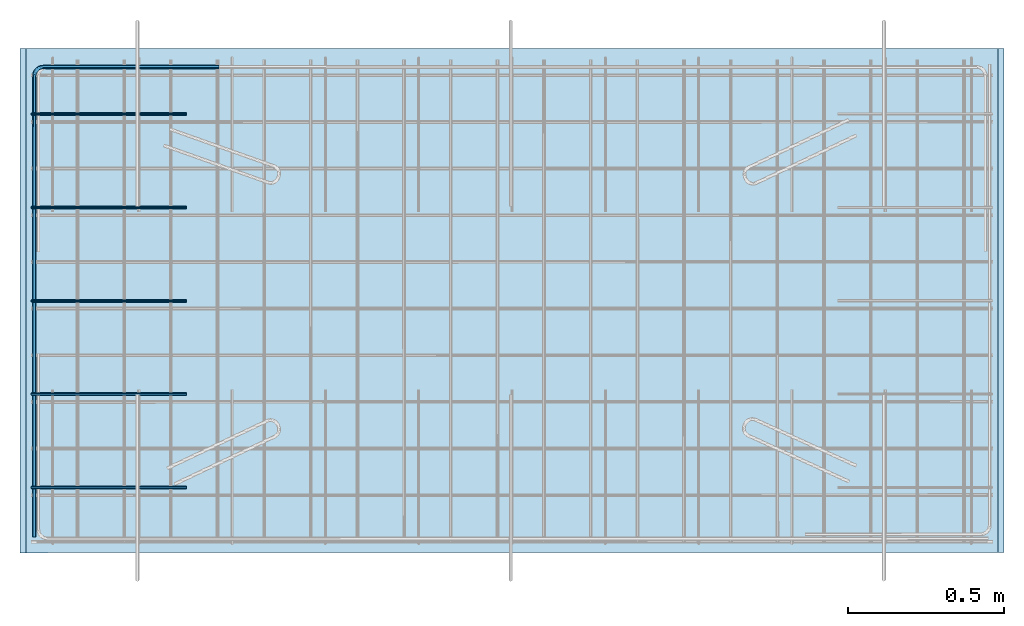
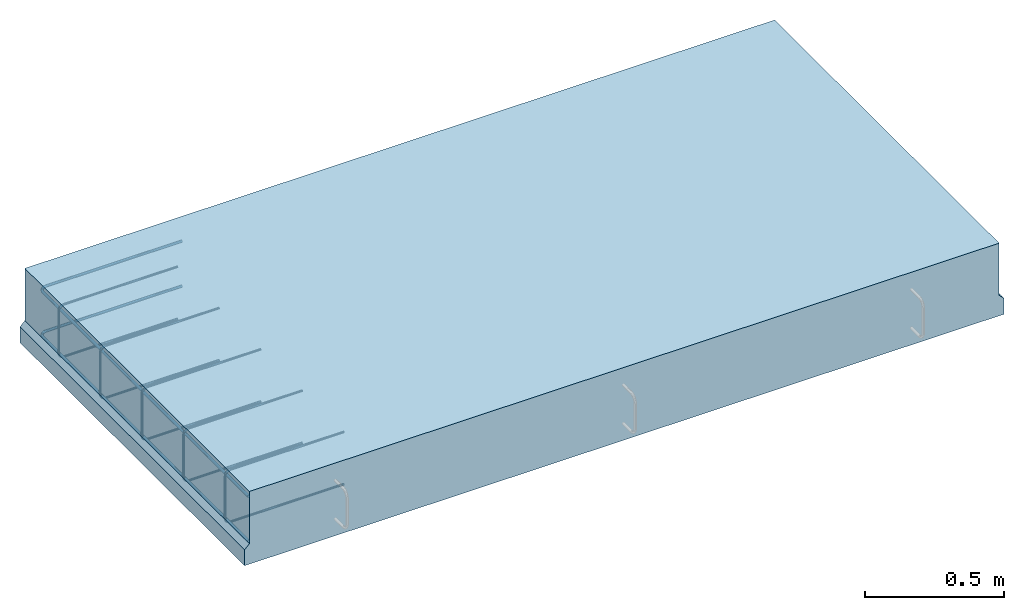
# One storey, part 1 of 6: 2 reinforcing bars, 1 slab, 1 element without a shape of its own.
"""IFC2X3 building model written with IfcOpenShell, lengths in millimetres."""

import ifcopenshell
import ifcopenshell.guid

model = None  # the IFC model being written
_history = None  # IfcOwnerHistory: only IFC2X3 demands one
_inside = {}  # id of a spatial element -> (the spatial element, [elements in it])
_under = {}  # id of a project, library or spatial element -> (it, [spatial elements below it])
_declared = {}  # id of a project -> (the project, [libraries it declares])
_typed = {}  # id of a type object -> (the type object, [elements of that type])
_made_of = {}  # id of a material, layer set ... -> (it, [elements and type objects made of it])


def new_model(schema):
    """Start an empty IFC model of exactly this schema.

    Asked for "IFC4X3", IfcOpenShell would pick the latest addendum, in which some entities
    have other attributes; the version numbers below select the first issue.
    IFC2X3 requires an IfcOwnerHistory on every rooted entity: one is made here for all.
    """
    global model, _history
    if schema == "IFC4X3":
        model = ifcopenshell.file(schema_version=(4, 3, 0, 0))
    else:
        model = ifcopenshell.file(schema=schema)
    _inside.clear()
    _under.clear()
    _declared.clear()
    _typed.clear()
    _made_of.clear()
    _history = None
    if model.schema == "IFC2X3":
        org = make("IfcOrganization", Name="unknown")
        user = make(
            "IfcPersonAndOrganization",
            ThePerson=make("IfcPerson", FamilyName="unknown"),
            TheOrganization=org,
        )
        app = make(
            "IfcApplication",
            ApplicationDeveloper=org,
            Version="unknown",
            ApplicationFullName="unknown",
            ApplicationIdentifier="unknown",
        )
        _history = make(
            "IfcOwnerHistory",
            OwningUser=user,
            OwningApplication=app,
            ChangeAction="ADDED",
            CreationDate=0,
        )
    return model


def make(cls, **values):
    """One entity of the class cls with the attributes given. An attribute that is None is left unset."""
    return model.create_entity(
        cls, **{name: value for name, value in values.items() if value is not None}
    )


def entity(cls, *values):
    """Any entity or typed value of the class cls, its attributes in the order of the schema. None: left unset."""
    e = model.create_entity(cls)
    for i, value in enumerate(values):
        if value is not None:
            e[i] = value
    return e


def rooted(cls, **values):
    """An entity with a GlobalId (a new one), such as an element, a storey or a relation."""
    return make(cls, GlobalId=ifcopenshell.guid.new(), OwnerHistory=_history, **values)


def si_unit(unit_type, name, prefix=None):
    """IfcSIUnit, for example si_unit("LENGTHUNIT", "METRE", prefix="MILLI")."""
    return make("IfcSIUnit", UnitType=unit_type, Prefix=prefix, Name=name)


def assignment(units):
    """IfcUnitAssignment: the units of a project."""
    return None if units is None else make("IfcUnitAssignment", Units=units)


def point(xyz):
    """IfcCartesianPoint."""
    return None if xyz is None else make("IfcCartesianPoint", Coordinates=xyz)


def direction(xyz):
    """IfcDirection."""
    return None if xyz is None else make("IfcDirection", DirectionRatios=xyz)


def frame(location, z_axis=None, x_axis=None):
    """IfcAxis2Placement3D, a coordinate frame: its origin and axes. An axis left out is left unset."""
    return make(
        "IfcAxis2Placement3D",
        Location=point(location),
        Axis=direction(z_axis),
        RefDirection=direction(x_axis),
    )


def origin_with_axes():
    """The frame at (0, 0, 0) with the z axis (0, 0, 1) and the x axis (1, 0, 0) written out."""
    return frame((0.0, 0.0, 0.0), z_axis=(0.0, 0.0, 1.0), x_axis=(1.0, 0.0, 0.0))


def place(relative_to, where):
    """IfcLocalPlacement: puts the frame where relative to a parent placement (None: the world)."""
    return make(
        "IfcLocalPlacement", PlacementRelTo=relative_to, RelativePlacement=where
    )


def context(
    kind, dimensions, precision=None, world=None, true_north=None, identifier=None
):
    """IfcGeometricRepresentationContext, for example the 3D "Model" context."""
    return make(
        "IfcGeometricRepresentationContext",
        ContextIdentifier=identifier,
        ContextType=kind,
        CoordinateSpaceDimension=dimensions,
        Precision=precision,
        WorldCoordinateSystem=world,
        TrueNorth=true_north,
    )


def subcontext(parent, identifier, kind, view, scale=None):
    """IfcGeometricRepresentationSubContext, for example "Body" below "Model"."""
    return make(
        "IfcGeometricRepresentationSubContext",
        ContextIdentifier=identifier,
        ContextType=kind,
        ParentContext=parent,
        TargetScale=scale,
        TargetView=view,
    )


def project(units=None, contexts=None):
    """IfcProject with its units and contexts."""
    return rooted(
        "IfcProject",
        Name="project",
        RepresentationContexts=contexts,
        UnitsInContext=assignment(units),
    )


def spatial(cls, under=None, at=None, **own):
    """A site, building, storey or space (cls), placed at a placement, below another one or the project."""
    s = rooted(cls, ObjectPlacement=at, **own)
    if under is not None:
        _under.setdefault(under.id(), (under, []))[1].append(s)
    return s


def faces_of(points, faces, orient=None, outer=None):
    """IfcFace entities. A face is a list of loops; a loop is a list of indices into points, from 0.

    orient and outer hold one flag for each loop. By default every Orientation is true, the
    first loop of a face is its IfcFaceOuterBound and the others are IfcFaceBound.
    """
    made = []
    for i, loops in enumerate(faces):
        bounds = []
        for j, loop in enumerate(loops):
            is_outer = j == 0 if outer is None else outer[i][j]
            bounds.append(
                make(
                    "IfcFaceOuterBound" if is_outer else "IfcFaceBound",
                    Bound=make("IfcPolyLoop", Polygon=[points[k] for k in loop]),
                    Orientation=True if orient is None else orient[i][j],
                )
            )
        made.append(make("IfcFace", Bounds=bounds))
    return made


def faceted_brep(points, faces, orient=None, outer=None, voids=None):
    """IfcFacetedBrep: a solid bounded by flat faces; with voids (closed shells), ...WithVoids."""
    shared = [point(p) for p in points]
    hull = make("IfcClosedShell", CfsFaces=faces_of(shared, faces, orient, outer))
    if voids is None:
        return make("IfcFacetedBrep", Outer=hull)
    return make(
        "IfcFacetedBrepWithVoids",
        Outer=hull,
        Voids=[
            make(cls, CfsFaces=faces_of(shared, fs, o, b)) for cls, fs, o, b in voids
        ],
    )


def shape(context_of_items, identifier, shape_type, items):
    """IfcShapeRepresentation: the items that make up one representation, for example the "Body"."""
    return make(
        "IfcShapeRepresentation",
        ContextOfItems=context_of_items,
        RepresentationIdentifier=identifier,
        RepresentationType=shape_type,
        Items=items,
    )


def source(mapping_origin, context_of_items, identifier, shape_type, items):
    """IfcRepresentationMap: a shape defined once, which mapped items show again and again."""
    return make(
        "IfcRepresentationMap",
        MappingOrigin=mapping_origin,
        MappedRepresentation=shape(context_of_items, identifier, shape_type, items),
    )


def transform(
    local_origin,
    x_axis=None,
    y_axis=None,
    z_axis=None,
    scale=None,
    scale2=None,
    scale3=None,
    uniform=True,
):
    """IfcCartesianTransformationOperator3D, or its non-uniform kind. x_axis, y_axis, z_axis: its Axis1, 2, 3."""
    if uniform:
        return make(
            "IfcCartesianTransformationOperator3D",
            Axis1=direction(x_axis),
            Axis2=direction(y_axis),
            LocalOrigin=point(local_origin),
            Scale=scale,
            Axis3=direction(z_axis),
        )
    return make(
        "IfcCartesianTransformationOperator3DnonUniform",
        Axis1=direction(x_axis),
        Axis2=direction(y_axis),
        LocalOrigin=point(local_origin),
        Scale=scale,
        Axis3=direction(z_axis),
        Scale2=scale2,
        Scale3=scale3,
    )


def mapped(mapping_source, mapping_target):
    """IfcMappedItem: shows the shape of a source again, moved by a transform."""
    return make(
        "IfcMappedItem", MappingSource=mapping_source, MappingTarget=mapping_target
    )


def material(Name=None, Category=None):
    """IfcMaterial."""
    return make("IfcMaterial", Name=Name, Category=Category)


def made_of(thing, what):
    """Note that an element or type object is made of a material, layer set ...; save() writes the relation."""
    if what is not None:
        _made_of.setdefault(what.id(), (what, []))[1].append(thing)
    return thing


def type_object(cls, material=None, **own):
    """A type object (cls), such as IfcWallType, which elements share."""
    return made_of(rooted(cls, **own), material)


def element(
    cls,
    number,
    at=None,
    inside=None,
    cuts=None,
    type_object=None,
    material=None,
    context=None,
    identifier="Body",
    shape_type=None,
    held_by="IfcProductDefinitionShape",
    body=None,
    shapes=None,
    **own,
):
    """One element of the class cls, such as IfcWall. Its Tag is "e" and its number.

    at: its placement. inside: the storey or other place that contains it. cuts: it is an
    opening in that element (IfcRelVoidsElement). A single representation is given by context,
    identifier, shape_type and body (its items); several are given by shapes. held_by: the class
    of the entity that holds the representations. save() writes the other relations.
    """
    e = rooted(cls, Tag="e%d" % number, ObjectPlacement=at, **own)
    if body is not None:
        shapes = [shape(context, identifier, shape_type, body)]
    if shapes is not None:
        e.Representation = make(held_by, Representations=shapes)
    if inside is not None:
        _inside.setdefault(inside.id(), (inside, []))[1].append(e)
    if cuts is not None:
        rooted(
            "IfcRelVoidsElement", RelatingBuildingElement=cuts, RelatedOpeningElement=e
        )
    if type_object is not None:
        _typed.setdefault(type_object.id(), (type_object, []))[1].append(e)
    return made_of(e, material)


def aggregate(whole, parts):
    """IfcRelAggregates: a whole, such as a stair, and the parts it consists of."""
    return rooted("IfcRelAggregates", RelatingObject=whole, RelatedObjects=parts)


def save(model, path):
    """Write the relations noted so far, then the file.

    IfcRelAggregates (storeys below a building ...), IfcRelContainedInSpatialStructure (elements
    in a storey), IfcRelDefinesByType, IfcRelAssociatesMaterial and IfcRelDeclares: one each for
    every whole, place, type object, material and project.
    """
    for whole, parts in _under.values():
        aggregate(whole, parts)
    for where, things in _inside.values():
        rooted(
            "IfcRelContainedInSpatialStructure",
            RelatedElements=things,
            RelatingStructure=where,
        )
    for kind, things in _typed.values():
        rooted("IfcRelDefinesByType", RelatedObjects=things, RelatingType=kind)
    for what, things in _made_of.values():
        rooted("IfcRelAssociatesMaterial", RelatedObjects=things, RelatingMaterial=what)
    for by, libraries in _declared.values():
        rooted("IfcRelDeclares", RelatingContext=by, RelatedDefinitions=libraries)
    model.write(path)


model = new_model("IFC2X3")

# Units and contexts
model_context = context("Model", 3, precision=1e-05, world=origin_with_axes())
body_context = subcontext(model_context, "Body", "Model", "MODEL_VIEW")
ifc_project = project(units=[si_unit("LENGTHUNIT", "METRE", prefix="MILLI"), si_unit("AREAUNIT", "SQUARE_METRE"), si_unit("VOLUMEUNIT", "CUBIC_METRE"), si_unit("MASSUNIT", "GRAM", prefix="KILO"), si_unit("TIMEUNIT", "SECOND"), si_unit("PLANEANGLEUNIT", "RADIAN"), si_unit("SOLIDANGLEUNIT", "STERADIAN"), si_unit("THERMODYNAMICTEMPERATUREUNIT", "DEGREE_CELSIUS"), si_unit("LUMINOUSINTENSITYUNIT", "LUMEN")], contexts=[model_context])

# Site, building, storey
site_placement = place(None, origin_with_axes())
site = spatial("IfcSite", under=ifc_project, at=site_placement, CompositionType="ELEMENT")
building_placement = place(site_placement, origin_with_axes())
building = spatial("IfcBuilding", under=site, at=building_placement, Name="1", CompositionType="ELEMENT")
storey_placement = place(building_placement, origin_with_axes())
storey = spatial("IfcBuildingStorey", under=building, at=storey_placement, Name="1. kerros", CompositionType="ELEMENT", Elevation=0.0)

# Assembly, slab, reinforcing bars
assembly_placement = place(storey_placement, origin_with_axes())
assembly = element("IfcElementAssembly", 1, at=assembly_placement, inside=storey, AssemblyPlace="NOTDEFINED", PredefinedType="REINFORCEMENT_UNIT")
ifc_material_1 = material(Name="CONCRETE/C30/37")
slab_type = type_object("IfcSlabType", Name="320X1621", PredefinedType="NOTDEFINED")
slab_placement = place(assembly_placement, frame((36000.0012643835, 17919.6722126255, 329.999999999999), z_axis=(-0.000103540999960387, 0.999999994639631, 0.0), x_axis=(0.999999994639631, 0.000103540999962941, 0.0)))
slab = element("IfcSlab", 2, at=slab_placement, type_object=slab_type, material=ifc_material_1, ObjectType="320X1621", PredefinedType="FLOOR", context=body_context, shape_type="Brep", body=[
    faceted_brep([(3143.72789859229, -160.000156232967, 1620.51611327888), (3143.5574067011, -160.0, -6.3228071667254e-09), (3143.55740107196, 69.999997454004, -0.000330025348375784), (3143.72789299664, 69.9999977242481, 1620.52209530753), (3163.73373855482, 89.9999949675926, 1620.51999052917), (3163.5556640625, 89.9999946973488, -6.36282493360341e-09), (20.1860801124567, -160.024558767086, 1620.51611290907), (20.1860790579158, 69.9854510249237, 1620.51611328126), (20.0155881749379, 70.0100098924999, 0.00358235149178654), (20.0155888627778, -160.0, -3.63797880709171e-11), (0.176325842738152, 89.9854512991945, 1620.51611328125), (0.0, 90.0100101302731, 3.63797880709171e-12), (0.176325842738152, 160.0, 1620.51611328125), (0.0, 160.0, 3.63797880709171e-12), (3163.72583007813, 160.0, 1620.51611328125), (3163.5556640625, 160.0, -6.36282493360341e-09)], [[[0, 1, 2, 3]], [[4, 3, 2, 5]], [[6, 7, 8, 9]], [[10, 11, 8, 7]], [[12, 13, 11, 10]], [[14, 15, 13, 12]], [[15, 14, 4, 5]], [[1, 9, 8, 11, 13, 15, 5, 2]], [[6, 9, 1, 0]], [[14, 12, 10, 7, 6, 0, 3, 4]]]),
])
ifc_material_2 = material(Name="B500B")
ifc_direction_1 = entity("IfcDirection", [-1.0, 0.0, 0.0])
ifc_direction_2 = entity("IfcDirection", [0.0, -1.0, 0.0])
shared_shape_1 = source(origin_with_axes(), body_context, "Body", "AdvancedSweptSolid", [
    entity("IfcSweptDiskSolid", entity("IfcCompositeCurve", [entity("IfcCompositeCurveSegment", "CONTINUOUS", True, entity("IfcTrimmedCurve", entity("IfcLine", entity("IfcCartesianPoint", [0.0, 0.0, 0.0]), entity("IfcVector", ifc_direction_1, 1.0)), [entity("IfcParameterValue", 0.0)], [entity("IfcParameterValue", 472.000000000704)], True, "PARAMETER")), entity("IfcCompositeCurveSegment", "CONTINUOUS", True, entity("IfcTrimmedCurve", entity("IfcCircle", entity("IfcAxis2Placement3D", entity("IfcCartesianPoint", [-472.000000000534, 0.00040020774633831, -23.0000000000025]), ifc_direction_2, entity("IfcDirection", [0.0, 0.0, 1.0])), 23.0), [entity("IfcParameterValue", 0.0)], [entity("IfcParameterValue", 1.57079632679416)], True, "PARAMETER")), entity("IfcCompositeCurveSegment", "CONTINUOUS", True, entity("IfcTrimmedCurve", entity("IfcLine", entity("IfcCartesianPoint", [-495.000000000526, 0.000419709393469248, -22.9999999999858]), entity("IfcVector", entity("IfcDirection", [0.0, 0.0, -1.0]), 1.0)), [entity("IfcParameterValue", 0.0)], [entity("IfcParameterValue", 183.999999999997)], True, "PARAMETER")), entity("IfcCompositeCurveSegment", "CONTINUOUS", True, entity("IfcTrimmedCurve", entity("IfcCircle", entity("IfcAxis2Placement3D", entity("IfcCartesianPoint", [-472.000000000668, 0.000400208176642991, -207.0]), ifc_direction_2, ifc_direction_1), 23.0), [entity("IfcParameterValue", 0.0)], [entity("IfcParameterValue", 1.57079632679563)], True, "PARAMETER")), entity("IfcCompositeCurveSegment", "DISCONTINUOUS", True, entity("IfcTrimmedCurve", entity("IfcLine", entity("IfcCartesianPoint", [-472.000000000668, 0.000400208207935293, -230.0]), entity("IfcVector", entity("IfcDirection", [1.0, 0.0, 0.0]), 1.0)), [entity("IfcParameterValue", 0.0)], [entity("IfcParameterValue", 472.000000000663)], True, "PARAMETER"))], False), 5.0, None, 0.0, 1131.14159265495),
])
ifc_direction_3 = entity("IfcDirection", [-1.0, 0.0, 0.0])
ifc_direction_4 = entity("IfcDirection", [0.0, -1.0, 0.0])
shared_shape_2 = source(origin_with_axes(), body_context, "Body", "AdvancedSweptSolid", [
    entity("IfcSweptDiskSolid", entity("IfcCompositeCurve", [entity("IfcCompositeCurveSegment", "CONTINUOUS", True, entity("IfcTrimmedCurve", entity("IfcLine", entity("IfcCartesianPoint", [0.0, 0.0, 0.0]), entity("IfcVector", ifc_direction_3, 1.0)), [entity("IfcParameterValue", 0.0)], [entity("IfcParameterValue", 472.000000000704)], True, "PARAMETER")), entity("IfcCompositeCurveSegment", "CONTINUOUS", True, entity("IfcTrimmedCurve", entity("IfcCircle", entity("IfcAxis2Placement3D", entity("IfcCartesianPoint", [-472.000000000534, 0.00040020774633831, -23.0000000000025]), ifc_direction_4, entity("IfcDirection", [0.0, 0.0, 1.0])), 23.0), [entity("IfcParameterValue", 0.0)], [entity("IfcParameterValue", 1.57079632679416)], True, "PARAMETER")), entity("IfcCompositeCurveSegment", "CONTINUOUS", True, entity("IfcTrimmedCurve", entity("IfcLine", entity("IfcCartesianPoint", [-495.000000000526, 0.000419709393469248, -22.9999999999858]), entity("IfcVector", entity("IfcDirection", [0.0, 0.0, -1.0]), 1.0)), [entity("IfcParameterValue", 0.0)], [entity("IfcParameterValue", 183.999999999997)], True, "PARAMETER")), entity("IfcCompositeCurveSegment", "CONTINUOUS", True, entity("IfcTrimmedCurve", entity("IfcCircle", entity("IfcAxis2Placement3D", entity("IfcCartesianPoint", [-472.000000000668, 0.000400208176642991, -207.0]), ifc_direction_4, ifc_direction_3), 23.0), [entity("IfcParameterValue", 0.0)], [entity("IfcParameterValue", 1.57079632679563)], True, "PARAMETER")), entity("IfcCompositeCurveSegment", "DISCONTINUOUS", True, entity("IfcTrimmedCurve", entity("IfcLine", entity("IfcCartesianPoint", [-472.000000000668, 0.000400208207935293, -230.0]), entity("IfcVector", entity("IfcDirection", [1.0, 0.0, 0.0]), 1.0)), [entity("IfcParameterValue", 0.0)], [entity("IfcParameterValue", 472.000000000663)], True, "PARAMETER"))], False), 5.0, None, 0.0, 1131.14159265495),
])
ifc_direction_5 = entity("IfcDirection", [-1.0, 0.0, 0.0])
ifc_direction_6 = entity("IfcDirection", [0.0, -1.0, 0.0])
shared_shape_3 = source(origin_with_axes(), body_context, "Body", "AdvancedSweptSolid", [
    entity("IfcSweptDiskSolid", entity("IfcCompositeCurve", [entity("IfcCompositeCurveSegment", "CONTINUOUS", True, entity("IfcTrimmedCurve", entity("IfcLine", entity("IfcCartesianPoint", [0.0, 0.0, 0.0]), entity("IfcVector", ifc_direction_5, 1.0)), [entity("IfcParameterValue", 0.0)], [entity("IfcParameterValue", 472.000000000711)], True, "PARAMETER")), entity("IfcCompositeCurveSegment", "CONTINUOUS", True, entity("IfcTrimmedCurve", entity("IfcCircle", entity("IfcAxis2Placement3D", entity("IfcCartesianPoint", [-472.000000000534, 0.00040020774633831, -23.0000000000025]), ifc_direction_6, entity("IfcDirection", [0.0, 0.0, 1.0])), 23.0), [entity("IfcParameterValue", 0.0)], [entity("IfcParameterValue", 1.57079632679416)], True, "PARAMETER")), entity("IfcCompositeCurveSegment", "CONTINUOUS", True, entity("IfcTrimmedCurve", entity("IfcLine", entity("IfcCartesianPoint", [-495.000000000526, 0.000419709393469248, -22.9999999999858]), entity("IfcVector", entity("IfcDirection", [0.0, 0.0, -1.0]), 1.0)), [entity("IfcParameterValue", 0.0)], [entity("IfcParameterValue", 183.999999999997)], True, "PARAMETER")), entity("IfcCompositeCurveSegment", "CONTINUOUS", True, entity("IfcTrimmedCurve", entity("IfcCircle", entity("IfcAxis2Placement3D", entity("IfcCartesianPoint", [-472.000000000668, 0.000400208176642991, -207.0]), ifc_direction_6, ifc_direction_5), 23.0), [entity("IfcParameterValue", 0.0)], [entity("IfcParameterValue", 1.57079632679563)], True, "PARAMETER")), entity("IfcCompositeCurveSegment", "DISCONTINUOUS", True, entity("IfcTrimmedCurve", entity("IfcLine", entity("IfcCartesianPoint", [-472.000000000668, 0.000400208207935293, -230.0]), entity("IfcVector", entity("IfcDirection", [1.0, 0.0, 0.0]), 1.0)), [entity("IfcParameterValue", 0.0)], [entity("IfcParameterValue", 472.000000000671)], True, "PARAMETER"))], False), 5.0, None, 0.0, 1131.14159265497),
])
ifc_direction_7 = entity("IfcDirection", [-1.0, 0.0, 0.0])
ifc_direction_8 = entity("IfcDirection", [0.0, -1.0, 0.0])
shared_shape_4 = source(origin_with_axes(), body_context, "Body", "AdvancedSweptSolid", [
    entity("IfcSweptDiskSolid", entity("IfcCompositeCurve", [entity("IfcCompositeCurveSegment", "CONTINUOUS", True, entity("IfcTrimmedCurve", entity("IfcLine", entity("IfcCartesianPoint", [0.0, 0.0, 0.0]), entity("IfcVector", ifc_direction_7, 1.0)), [entity("IfcParameterValue", 0.0)], [entity("IfcParameterValue", 472.000000000711)], True, "PARAMETER")), entity("IfcCompositeCurveSegment", "CONTINUOUS", True, entity("IfcTrimmedCurve", entity("IfcCircle", entity("IfcAxis2Placement3D", entity("IfcCartesianPoint", [-472.000000000534, 0.00040020774633831, -23.0000000000025]), ifc_direction_8, entity("IfcDirection", [0.0, 0.0, 1.0])), 23.0), [entity("IfcParameterValue", 0.0)], [entity("IfcParameterValue", 1.57079632679416)], True, "PARAMETER")), entity("IfcCompositeCurveSegment", "CONTINUOUS", True, entity("IfcTrimmedCurve", entity("IfcLine", entity("IfcCartesianPoint", [-495.000000000526, 0.000419709393469248, -22.9999999999858]), entity("IfcVector", entity("IfcDirection", [0.0, 0.0, -1.0]), 1.0)), [entity("IfcParameterValue", 0.0)], [entity("IfcParameterValue", 183.999999999997)], True, "PARAMETER")), entity("IfcCompositeCurveSegment", "CONTINUOUS", True, entity("IfcTrimmedCurve", entity("IfcCircle", entity("IfcAxis2Placement3D", entity("IfcCartesianPoint", [-472.000000000668, 0.000400208176642991, -207.0]), ifc_direction_8, ifc_direction_7), 23.0), [entity("IfcParameterValue", 0.0)], [entity("IfcParameterValue", 1.57079632679563)], True, "PARAMETER")), entity("IfcCompositeCurveSegment", "DISCONTINUOUS", True, entity("IfcTrimmedCurve", entity("IfcLine", entity("IfcCartesianPoint", [-472.000000000668, 0.000400208207935293, -230.0]), entity("IfcVector", entity("IfcDirection", [1.0, 0.0, 0.0]), 1.0)), [entity("IfcParameterValue", 0.0)], [entity("IfcParameterValue", 472.000000000671)], True, "PARAMETER"))], False), 5.0, None, 0.0, 1131.14159265497),
])
ifc_direction_9 = entity("IfcDirection", [-1.0, 0.0, 0.0])
ifc_direction_10 = entity("IfcDirection", [0.0, -1.0, 0.0])
shared_shape_5 = source(origin_with_axes(), body_context, "Body", "AdvancedSweptSolid", [
    entity("IfcSweptDiskSolid", entity("IfcCompositeCurve", [entity("IfcCompositeCurveSegment", "CONTINUOUS", True, entity("IfcTrimmedCurve", entity("IfcLine", entity("IfcCartesianPoint", [0.0, 0.0, 0.0]), entity("IfcVector", ifc_direction_9, 1.0)), [entity("IfcParameterValue", 0.0)], [entity("IfcParameterValue", 472.000000000704)], True, "PARAMETER")), entity("IfcCompositeCurveSegment", "CONTINUOUS", True, entity("IfcTrimmedCurve", entity("IfcCircle", entity("IfcAxis2Placement3D", entity("IfcCartesianPoint", [-472.000000000534, 0.00040020774633831, -23.0000000000025]), ifc_direction_10, entity("IfcDirection", [0.0, 0.0, 1.0])), 23.0), [entity("IfcParameterValue", 0.0)], [entity("IfcParameterValue", 1.57079632679416)], True, "PARAMETER")), entity("IfcCompositeCurveSegment", "CONTINUOUS", True, entity("IfcTrimmedCurve", entity("IfcLine", entity("IfcCartesianPoint", [-495.000000000526, 0.000419709393469248, -22.9999999999858]), entity("IfcVector", entity("IfcDirection", [0.0, 0.0, -1.0]), 1.0)), [entity("IfcParameterValue", 0.0)], [entity("IfcParameterValue", 183.999999999997)], True, "PARAMETER")), entity("IfcCompositeCurveSegment", "CONTINUOUS", True, entity("IfcTrimmedCurve", entity("IfcCircle", entity("IfcAxis2Placement3D", entity("IfcCartesianPoint", [-472.000000000668, 0.000400208176642991, -207.0]), ifc_direction_10, ifc_direction_9), 23.0), [entity("IfcParameterValue", 0.0)], [entity("IfcParameterValue", 1.57079632679563)], True, "PARAMETER")), entity("IfcCompositeCurveSegment", "DISCONTINUOUS", True, entity("IfcTrimmedCurve", entity("IfcLine", entity("IfcCartesianPoint", [-472.000000000668, 0.000400208207935293, -230.0]), entity("IfcVector", entity("IfcDirection", [1.0, 0.0, 0.0]), 1.0)), [entity("IfcParameterValue", 0.0)], [entity("IfcParameterValue", 472.000000000663)], True, "PARAMETER"))], False), 5.0, None, 0.0, 1131.14159265495),
])
reinforcing_bar_1_placement = place(assembly_placement, frame((36000.0983373852, 17919.675949679, 489.999999999999), z_axis=(0.0, 0.0, -1.0), x_axis=(0.999999999998611, -1.66700000046993e-06, 0.0)))
reinforcing_bar_1 = element("IfcReinforcingBar", 3, at=reinforcing_bar_1_placement, material=ifc_material_2, BarRole="NOTDEFINED", CrossSectionArea=0.0, NominalDiameter=10.0, context=body_context, shape_type="MappedRepresentation", body=[
    mapped(shared_shape_1, transform((534.903682914606, -209.996716605754, 274.999999999999))),
    mapped(shared_shape_2, transform((534.90476315569, -509.996716604222, 274.999999999999))),
    mapped(shared_shape_3, transform((534.905843396773, -809.996716602702, 274.999999999998))),
    mapped(shared_shape_4, transform((534.906923637849, -1109.99671660117, 274.999999999997))),
    mapped(shared_shape_5, transform((534.908003878933, -1409.99671659964, 274.999999999997))),
])
shared_shape_6 = source(origin_with_axes(), body_context, "Body", "AdvancedSweptSolid", [
    entity("IfcSweptDiskSolid", entity("IfcCompositeCurve", [entity("IfcCompositeCurveSegment", "CONTINUOUS", True, entity("IfcTrimmedCurve", entity("IfcLine", entity("IfcCartesianPoint", [0.0, 0.0, 0.0]), entity("IfcVector", entity("IfcDirection", [0.0, 0.0, -1.0]), 1.0)), [entity("IfcParameterValue", 0.0)], [entity("IfcParameterValue", 1482.51609601567)], True, "PARAMETER")), entity("IfcCompositeCurveSegment", "CONTINUOUS", True, entity("IfcTrimmedCurve", entity("IfcCircle", entity("IfcAxis2Placement3D", entity("IfcCartesianPoint", [29.0000002370342, 0.0, -1482.51609601103]), entity("IfcDirection", [0.0, -1.0, 0.0]), entity("IfcDirection", [-1.0, 0.0, 0.0])), 29.0), [entity("IfcParameterValue", 0.0)], [entity("IfcParameterValue", 1.57079632663382)], True, "PARAMETER")), entity("IfcCompositeCurveSegment", "DISCONTINUOUS", True, entity("IfcTrimmedCurve", entity("IfcLine", entity("IfcCartesianPoint", [29.0000002369998, 0.0, -1511.51609601103]), entity("IfcVector", entity("IfcDirection", [1.0, 0.0, 0.0]), 1.0)), [entity("IfcParameterValue", 0.0)], [entity("IfcParameterValue", 565.000000005188)], True, "PARAMETER"))], False), 6.0, None, 0.0, 2049.08689234749),
])
shared_shape_7 = source(origin_with_axes(), body_context, "Body", "AdvancedSweptSolid", [
    entity("IfcSweptDiskSolid", entity("IfcCompositeCurve", [entity("IfcCompositeCurveSegment", "CONTINUOUS", True, entity("IfcTrimmedCurve", entity("IfcLine", entity("IfcCartesianPoint", [0.0, 0.0, 0.0]), entity("IfcVector", entity("IfcDirection", [0.0, 0.0, -1.0]), 1.0)), [entity("IfcParameterValue", 0.0)], [entity("IfcParameterValue", 1482.51609601567)], True, "PARAMETER")), entity("IfcCompositeCurveSegment", "CONTINUOUS", True, entity("IfcTrimmedCurve", entity("IfcCircle", entity("IfcAxis2Placement3D", entity("IfcCartesianPoint", [29.0000002370342, 0.0, -1482.51609601103]), entity("IfcDirection", [0.0, -1.0, 0.0]), entity("IfcDirection", [-1.0, 0.0, 0.0])), 29.0), [entity("IfcParameterValue", 0.0)], [entity("IfcParameterValue", 1.57079632663382)], True, "PARAMETER")), entity("IfcCompositeCurveSegment", "DISCONTINUOUS", True, entity("IfcTrimmedCurve", entity("IfcLine", entity("IfcCartesianPoint", [29.0000002369998, 0.0, -1511.51609601103]), entity("IfcVector", entity("IfcDirection", [1.0, 0.0, 0.0]), 1.0)), [entity("IfcParameterValue", 0.0)], [entity("IfcParameterValue", 565.000000005188)], True, "PARAMETER"))], False), 6.0, None, 0.0, 2049.08689234749),
])
reinforcing_bar_2_placement = place(assembly_placement, frame((36000.0097999942, 19540.1882999942, 170.0), z_axis=(-5.24500000028638e-06, -0.999999999986245, 0.0), x_axis=(0.999999999986245, -5.24500000028636e-06, 0.0)))
reinforcing_bar_2 = element("IfcReinforcingBar", 4, at=reinforcing_bar_2_placement, material=ifc_material_2, BarRole="NOTDEFINED", CrossSectionArea=0.0, NominalDiameter=12.0, context=body_context, shape_type="MappedRepresentation", body=[
    mapped(shared_shape_6, transform((45.9999997488558, 61.0, 1570.5160960109))),
    mapped(shared_shape_7, transform((45.9999997488558, 259.000000000003, 1570.5160960109))),
])
aggregate(assembly, [slab, reinforcing_bar_1, reinforcing_bar_2])

save(model, "model.ifc")
